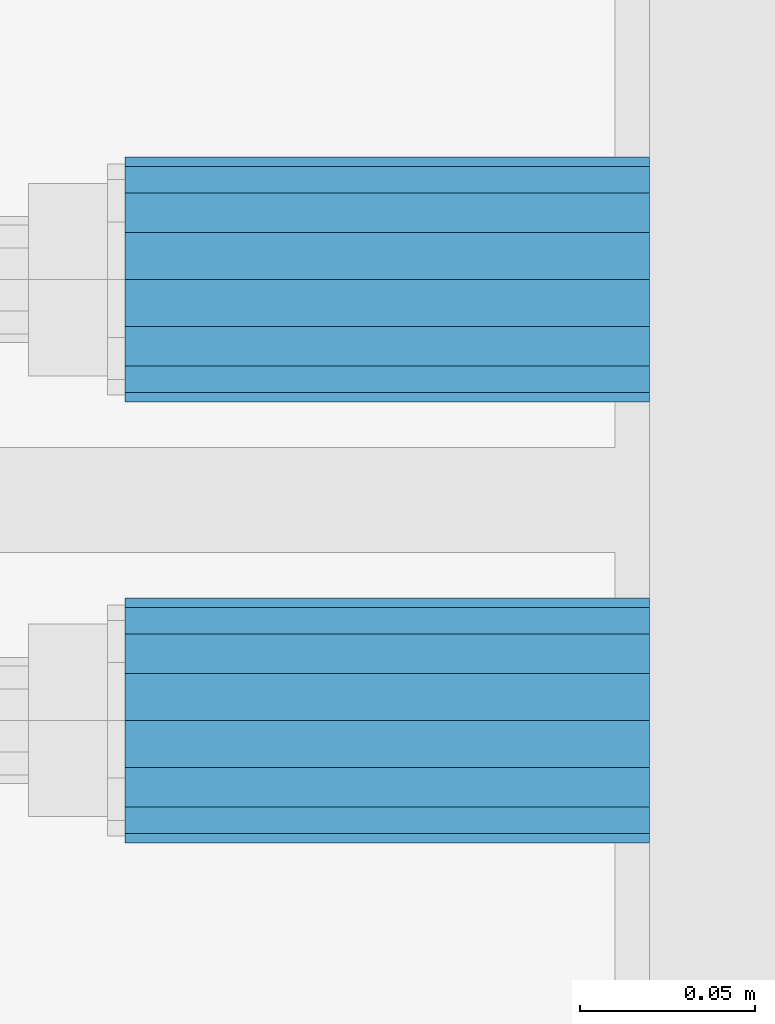
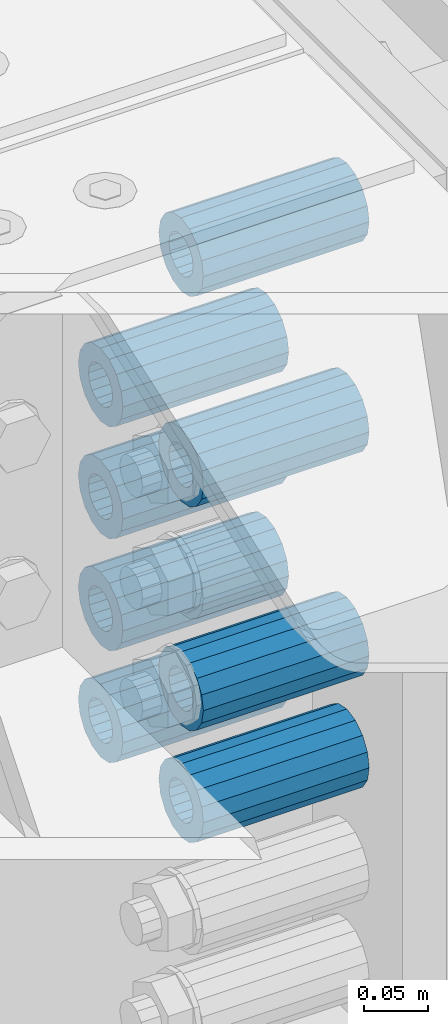
# One storey, part 159 of 242: 8 beams.
"""IFC2X3 building model written with IfcOpenShell, lengths in millimetres."""

from ifc_helpers import new_model, si_unit, frame, origin_with_axes, place, context, subcontext, project, spatial, faceted_brep, material, type_object, element, save


model = new_model("IFC2X3")

# Units and contexts
model_context = context("Model", 3, precision=1e-05, world=origin_with_axes())
body_context = subcontext(model_context, "Body", "Model", "MODEL_VIEW")
ifc_project = project(units=[si_unit("LENGTHUNIT", "METRE", prefix="MILLI"), si_unit("AREAUNIT", "SQUARE_METRE"), si_unit("VOLUMEUNIT", "CUBIC_METRE"), si_unit("MASSUNIT", "GRAM", prefix="KILO"), si_unit("TIMEUNIT", "SECOND"), si_unit("PLANEANGLEUNIT", "RADIAN"), si_unit("SOLIDANGLEUNIT", "STERADIAN"), si_unit("THERMODYNAMICTEMPERATUREUNIT", "DEGREE_CELSIUS"), si_unit("LUMINOUSINTENSITYUNIT", "LUMEN")], contexts=[model_context])

# Site, building, storey
site_placement = place(None, origin_with_axes())
site = spatial("IfcSite", under=ifc_project, at=site_placement, CompositionType="ELEMENT")
building_placement = place(site_placement, origin_with_axes())
building = spatial("IfcBuilding", under=site, at=building_placement, Name="Standard", CompositionType="ELEMENT")
storey_placement = place(building_placement, origin_with_axes())
storey = spatial("IfcBuildingStorey", under=building, at=storey_placement, Name="Undefined", CompositionType="ELEMENT", Elevation=0.0)

# Beams
ifc_material = material()
beam_type = type_object("IfcBeamType", PredefinedType="NOTDEFINED")
beam_1_placement = place(storey_placement, frame((-22210.0, -20937.0, -290.0), z_axis=(0.0, 0.0, 1.0), x_axis=(1.0, 0.0, 0.0)))
element("IfcBeam", 1, at=beam_1_placement, inside=storey, type_object=beam_type, material=ifc_material, context=body_context, shape_type="Brep", body=[
    faceted_brep([(1.33248249767348e-07, -19.0000000004493, -6.26823748461902e-09), (0.0, -17.5537111177146, 7.27098521493673), (150.0, -17.5537111177146, 7.27098521493673), (150.0, -19.0, 0.0), (0.0, -13.4350288425449, 13.4350288425444), (150.0, -13.4350288425449, 13.4350288425444), (0.0, -7.27098521493826, 17.5537111177144), (150.0, -7.27098521493826, 17.5537111177144), (-6.29370333626866e-09, -4.49290382675827e-10, 18.9999999937318), (150.0, 0.0, 19.0), (0.0, 7.27098521493826, 17.5537111177144), (150.0, 7.27098521493826, 17.5537111177144), (0.0, 13.4350288425449, 13.4350288425444), (150.0, 13.4350288425449, 13.4350288425444), (0.0, 17.5537111177146, 7.2709852149367), (150.0, 17.5537111177146, 7.2709852149367), (-1.31243723444641e-07, 18.9999999995507, -6.26823748461902e-09), (150.0, 19.0, 0.0), (0.0, 17.5537111177146, -7.2709852149367), (150.0, 17.5537111177146, -7.2709852149367), (0.0, 13.4350288425449, -13.4350288425444), (150.0, 13.4350288425449, -13.4350288425444), (0.0, 7.27098521493826, -17.5537111177144), (150.0, 7.27098521493826, -17.5537111177144), (8.2982296589762e-09, -4.49290382675827e-10, -19.0000000062719), (150.0, 0.0, -19.0), (0.0, -7.27098521493826, -17.5537111177144), (150.0, -7.27098521493826, -17.5537111177144), (0.0, -13.4350288425449, -13.4350288425444), (150.0, -13.4350288425449, -13.4350288425444), (0.0, -17.5537111177146, -7.2709852149367), (150.0, -17.5537111177146, -7.2709852149367), (-3.63797880709171e-12, -35.0, 0.0), (-3.63797880709171e-12, -32.335783637895, -13.3939201327812), (150.0, -32.3357836378964, -13.3939201327782), (150.0, -35.0, 0.0), (0.0, -24.7487373415292, -24.7487373415315), (150.0, -24.7487373415279, -24.7487373415292), (0.0, -13.3939201327782, -32.3357836378964), (150.0, -13.3939201327776, -32.335783637895), (0.0, 0.0, -35.0000000000036), (150.0, 0.0, -35.0), (0.0, 13.3939201327782, -32.3357836378964), (150.0, 13.3939201327776, -32.335783637895), (0.0, 24.7487373415292, -24.7487373415315), (150.0, 24.7487373415279, -24.7487373415292), (-3.63797880709171e-12, 32.335783637895, -13.3939201327812), (150.0, 32.3357836378964, -13.3939201327781), (-3.63797880709171e-12, 35.0, 0.0), (150.0, 35.0, 0.0), (-7.27595761418343e-12, 32.335783637895, 13.3939201327739), (150.0, 32.3357836378964, 13.3939201327781), (-7.27595761418343e-12, 24.7487373415292, 24.7487373415242), (150.0, 24.7487373415279, 24.7487373415292), (-7.27595761418343e-12, 13.3939201327781, 32.3357836378891), (150.0, 13.3939201327776, 32.335783637895), (-1.09139364212751e-11, 0.0, 34.9999999999964), (150.0, 0.0, 35.0), (-7.27595761418343e-12, -13.3939201327781, 32.3357836378891), (150.0, -13.3939201327776, 32.335783637895), (-7.27595761418343e-12, -24.7487373415292, 24.7487373415242), (150.0, -24.7487373415279, 24.7487373415292), (-7.27595761418343e-12, -32.335783637895, 13.3939201327739), (150.0, -32.3357836378964, 13.3939201327781)], [[[0, 1, 2, 3]], [[1, 4, 5, 2]], [[4, 6, 7, 5]], [[6, 8, 9, 7]], [[8, 10, 11, 9]], [[10, 12, 13, 11]], [[12, 14, 15, 13]], [[14, 16, 17, 15]], [[16, 18, 19, 17]], [[18, 20, 21, 19]], [[20, 22, 23, 21]], [[22, 24, 25, 23]], [[24, 26, 27, 25]], [[26, 28, 29, 27]], [[28, 30, 31, 29]], [[30, 0, 3, 31]], [[32, 33, 34, 35]], [[33, 36, 37, 34]], [[36, 38, 39, 37]], [[38, 40, 41, 39]], [[40, 42, 43, 41]], [[42, 44, 45, 43]], [[44, 46, 47, 45]], [[46, 48, 49, 47]], [[48, 50, 51, 49]], [[50, 52, 53, 51]], [[52, 54, 55, 53]], [[54, 56, 57, 55]], [[56, 58, 59, 57]], [[58, 60, 61, 59]], [[60, 62, 63, 61]], [[62, 32, 35, 63]], [[37, 39, 41, 43, 45, 47, 49, 51, 53, 55, 57, 59, 61, 63, 35, 34], [5, 7, 9, 11, 13, 15, 17, 19, 21, 23, 25, 27, 29, 31, 3, 2]], [[62, 60, 58, 56, 54, 52, 50, 48, 46, 44, 42, 40, 38, 36, 33, 32], [30, 28, 26, 24, 22, 20, 18, 16, 14, 12, 10, 8, 6, 4, 1, 0]]]),
])
beam_2_placement = place(storey_placement, frame((-22210.0, -20937.0, -504.0), z_axis=(0.0, 0.0, 1.0), x_axis=(1.0, 0.0, 0.0)))
element("IfcBeam", 2, at=beam_2_placement, inside=storey, type_object=beam_type, material=ifc_material, context=body_context, shape_type="Brep", body=[
    faceted_brep([(1.33248249767348e-07, -19.0000000004493, -6.26823748461902e-09), (0.0, -17.5537111177146, 7.27098521493673), (150.0, -17.5537111177146, 7.27098521493673), (150.0, -19.0, 0.0), (0.0, -13.4350288425449, 13.4350288425444), (150.0, -13.4350288425449, 13.4350288425444), (0.0, -7.27098521493826, 17.5537111177144), (150.0, -7.27098521493826, 17.5537111177144), (-6.29370333626866e-09, -4.49290382675827e-10, 18.9999999937318), (150.0, 0.0, 19.0), (0.0, 7.27098521493826, 17.5537111177144), (150.0, 7.27098521493826, 17.5537111177144), (0.0, 13.4350288425449, 13.4350288425444), (150.0, 13.4350288425449, 13.4350288425444), (0.0, 17.5537111177146, 7.2709852149367), (150.0, 17.5537111177146, 7.2709852149367), (-1.31243723444641e-07, 18.9999999995507, -6.26823748461902e-09), (150.0, 19.0, 0.0), (0.0, 17.5537111177146, -7.2709852149367), (150.0, 17.5537111177146, -7.2709852149367), (0.0, 13.4350288425449, -13.4350288425444), (150.0, 13.4350288425449, -13.4350288425444), (0.0, 7.27098521493826, -17.5537111177144), (150.0, 7.27098521493826, -17.5537111177144), (8.2982296589762e-09, -4.49290382675827e-10, -19.0000000062719), (150.0, 0.0, -19.0), (0.0, -7.27098521493826, -17.5537111177144), (150.0, -7.27098521493826, -17.5537111177144), (0.0, -13.4350288425449, -13.4350288425444), (150.0, -13.4350288425449, -13.4350288425444), (0.0, -17.5537111177146, -7.2709852149367), (150.0, -17.5537111177146, -7.2709852149367), (-3.63797880709171e-12, -35.0, 0.0), (-3.63797880709171e-12, -32.335783637895, -13.3939201327812), (150.0, -32.3357836378964, -13.3939201327782), (150.0, -35.0, 0.0), (0.0, -24.7487373415292, -24.7487373415315), (150.0, -24.7487373415279, -24.7487373415292), (0.0, -13.3939201327782, -32.3357836378964), (150.0, -13.3939201327776, -32.335783637895), (0.0, 0.0, -35.0000000000036), (150.0, 0.0, -35.0), (0.0, 13.3939201327782, -32.3357836378964), (150.0, 13.3939201327776, -32.335783637895), (0.0, 24.7487373415292, -24.7487373415315), (150.0, 24.7487373415279, -24.7487373415292), (-3.63797880709171e-12, 32.335783637895, -13.3939201327812), (150.0, 32.3357836378964, -13.3939201327781), (-3.63797880709171e-12, 35.0, 0.0), (150.0, 35.0, 0.0), (-7.27595761418343e-12, 32.335783637895, 13.3939201327739), (150.0, 32.3357836378964, 13.3939201327781), (-7.27595761418343e-12, 24.7487373415292, 24.7487373415242), (150.0, 24.7487373415279, 24.7487373415292), (-7.27595761418343e-12, 13.3939201327781, 32.3357836378891), (150.0, 13.3939201327776, 32.335783637895), (-1.09139364212751e-11, 0.0, 34.9999999999964), (150.0, 0.0, 35.0), (-7.27595761418343e-12, -13.3939201327781, 32.3357836378891), (150.0, -13.3939201327776, 32.335783637895), (-7.27595761418343e-12, -24.7487373415292, 24.7487373415242), (150.0, -24.7487373415279, 24.7487373415292), (-7.27595761418343e-12, -32.335783637895, 13.3939201327739), (150.0, -32.3357836378964, 13.3939201327781)], [[[0, 1, 2, 3]], [[1, 4, 5, 2]], [[4, 6, 7, 5]], [[6, 8, 9, 7]], [[8, 10, 11, 9]], [[10, 12, 13, 11]], [[12, 14, 15, 13]], [[14, 16, 17, 15]], [[16, 18, 19, 17]], [[18, 20, 21, 19]], [[20, 22, 23, 21]], [[22, 24, 25, 23]], [[24, 26, 27, 25]], [[26, 28, 29, 27]], [[28, 30, 31, 29]], [[30, 0, 3, 31]], [[32, 33, 34, 35]], [[33, 36, 37, 34]], [[36, 38, 39, 37]], [[38, 40, 41, 39]], [[40, 42, 43, 41]], [[42, 44, 45, 43]], [[44, 46, 47, 45]], [[46, 48, 49, 47]], [[48, 50, 51, 49]], [[50, 52, 53, 51]], [[52, 54, 55, 53]], [[54, 56, 57, 55]], [[56, 58, 59, 57]], [[58, 60, 61, 59]], [[60, 62, 63, 61]], [[62, 32, 35, 63]], [[37, 39, 41, 43, 45, 47, 49, 51, 53, 55, 57, 59, 61, 63, 35, 34], [5, 7, 9, 11, 13, 15, 17, 19, 21, 23, 25, 27, 29, 31, 3, 2]], [[62, 60, 58, 56, 54, 52, 50, 48, 46, 44, 42, 40, 38, 36, 33, 32], [30, 28, 26, 24, 22, 20, 18, 16, 14, 12, 10, 8, 6, 4, 1, 0]]]),
])
beam_3_placement = place(storey_placement, frame((-22210.0, -20937.0, -611.0), z_axis=(0.0, 0.0, 1.0), x_axis=(1.0, 0.0, 0.0)))
element("IfcBeam", 3, at=beam_3_placement, inside=storey, type_object=beam_type, material=ifc_material, context=body_context, shape_type="Brep", body=[
    faceted_brep([(1.33248249767348e-07, -19.0000000004493, -6.26823748461902e-09), (0.0, -17.5537111177146, 7.27098521493673), (150.0, -17.5537111177146, 7.27098521493673), (150.0, -19.0, 0.0), (0.0, -13.4350288425449, 13.4350288425444), (150.0, -13.4350288425449, 13.4350288425444), (0.0, -7.27098521493826, 17.5537111177144), (150.0, -7.27098521493826, 17.5537111177144), (-6.29370333626866e-09, -4.49290382675827e-10, 18.9999999937318), (150.0, 0.0, 19.0), (0.0, 7.27098521493826, 17.5537111177144), (150.0, 7.27098521493826, 17.5537111177144), (0.0, 13.4350288425449, 13.4350288425444), (150.0, 13.4350288425449, 13.4350288425444), (0.0, 17.5537111177146, 7.2709852149367), (150.0, 17.5537111177146, 7.2709852149367), (-1.31243723444641e-07, 18.9999999995507, -6.26823748461902e-09), (150.0, 19.0, 0.0), (0.0, 17.5537111177146, -7.2709852149367), (150.0, 17.5537111177146, -7.2709852149367), (0.0, 13.4350288425449, -13.4350288425444), (150.0, 13.4350288425449, -13.4350288425444), (0.0, 7.27098521493826, -17.5537111177144), (150.0, 7.27098521493826, -17.5537111177144), (8.2982296589762e-09, -4.49290382675827e-10, -19.0000000062719), (150.0, 0.0, -19.0), (0.0, -7.27098521493826, -17.5537111177144), (150.0, -7.27098521493826, -17.5537111177144), (0.0, -13.4350288425449, -13.4350288425444), (150.0, -13.4350288425449, -13.4350288425444), (0.0, -17.5537111177146, -7.2709852149367), (150.0, -17.5537111177146, -7.2709852149367), (-3.63797880709171e-12, -35.0, 0.0), (-3.63797880709171e-12, -32.335783637895, -13.3939201327812), (150.0, -32.3357836378964, -13.3939201327782), (150.0, -35.0, 0.0), (0.0, -24.7487373415292, -24.7487373415315), (150.0, -24.7487373415279, -24.7487373415292), (0.0, -13.3939201327782, -32.3357836378964), (150.0, -13.3939201327776, -32.335783637895), (0.0, 0.0, -35.0000000000036), (150.0, 0.0, -35.0), (0.0, 13.3939201327782, -32.3357836378964), (150.0, 13.3939201327776, -32.335783637895), (0.0, 24.7487373415292, -24.7487373415315), (150.0, 24.7487373415279, -24.7487373415292), (-3.63797880709171e-12, 32.335783637895, -13.3939201327812), (150.0, 32.3357836378964, -13.3939201327781), (-3.63797880709171e-12, 35.0, 0.0), (150.0, 35.0, 0.0), (-7.27595761418343e-12, 32.335783637895, 13.3939201327739), (150.0, 32.3357836378964, 13.3939201327781), (-7.27595761418343e-12, 24.7487373415292, 24.7487373415242), (150.0, 24.7487373415279, 24.7487373415292), (-7.27595761418343e-12, 13.3939201327781, 32.3357836378891), (150.0, 13.3939201327776, 32.335783637895), (-1.09139364212751e-11, 0.0, 34.9999999999964), (150.0, 0.0, 35.0), (-7.27595761418343e-12, -13.3939201327781, 32.3357836378891), (150.0, -13.3939201327776, 32.335783637895), (-7.27595761418343e-12, -24.7487373415292, 24.7487373415242), (150.0, -24.7487373415279, 24.7487373415292), (-7.27595761418343e-12, -32.335783637895, 13.3939201327739), (150.0, -32.3357836378964, 13.3939201327781)], [[[0, 1, 2, 3]], [[1, 4, 5, 2]], [[4, 6, 7, 5]], [[6, 8, 9, 7]], [[8, 10, 11, 9]], [[10, 12, 13, 11]], [[12, 14, 15, 13]], [[14, 16, 17, 15]], [[16, 18, 19, 17]], [[18, 20, 21, 19]], [[20, 22, 23, 21]], [[22, 24, 25, 23]], [[24, 26, 27, 25]], [[26, 28, 29, 27]], [[28, 30, 31, 29]], [[30, 0, 3, 31]], [[32, 33, 34, 35]], [[33, 36, 37, 34]], [[36, 38, 39, 37]], [[38, 40, 41, 39]], [[40, 42, 43, 41]], [[42, 44, 45, 43]], [[44, 46, 47, 45]], [[46, 48, 49, 47]], [[48, 50, 51, 49]], [[50, 52, 53, 51]], [[52, 54, 55, 53]], [[54, 56, 57, 55]], [[56, 58, 59, 57]], [[58, 60, 61, 59]], [[60, 62, 63, 61]], [[62, 32, 35, 63]], [[37, 39, 41, 43, 45, 47, 49, 51, 53, 55, 57, 59, 61, 63, 35, 34], [5, 7, 9, 11, 13, 15, 17, 19, 21, 23, 25, 27, 29, 31, 3, 2]], [[62, 60, 58, 56, 54, 52, 50, 48, 46, 44, 42, 40, 38, 36, 33, 32], [30, 28, 26, 24, 22, 20, 18, 16, 14, 12, 10, 8, 6, 4, 1, 0]]]),
])
beam_4_placement = place(storey_placement, frame((-22210.0, -21063.0, -89.0000000000001), z_axis=(0.0, 0.0, 1.0), x_axis=(1.0, 0.0, 0.0)))
element("IfcBeam", 4, at=beam_4_placement, inside=storey, type_object=beam_type, material=ifc_material, context=body_context, shape_type="Brep", body=[
    faceted_brep([(1.33248249767348e-07, -19.0000000004493, -6.26823748461902e-09), (0.0, -17.5537111177146, 7.27098521493673), (150.0, -17.5537111177146, 7.27098521493673), (150.0, -19.0, 0.0), (0.0, -13.4350288425449, 13.4350288425444), (150.0, -13.4350288425449, 13.4350288425444), (0.0, -7.27098521493826, 17.5537111177144), (150.0, -7.27098521493826, 17.5537111177144), (-6.29370333626866e-09, -4.49290382675827e-10, 18.9999999937318), (150.0, 0.0, 19.0), (0.0, 7.27098521493826, 17.5537111177144), (150.0, 7.27098521493826, 17.5537111177144), (0.0, 13.4350288425449, 13.4350288425444), (150.0, 13.4350288425449, 13.4350288425444), (0.0, 17.5537111177146, 7.2709852149367), (150.0, 17.5537111177146, 7.2709852149367), (-1.31243723444641e-07, 18.9999999995507, -6.26823748461902e-09), (150.0, 19.0, 0.0), (0.0, 17.5537111177146, -7.2709852149367), (150.0, 17.5537111177146, -7.2709852149367), (0.0, 13.4350288425449, -13.4350288425444), (150.0, 13.4350288425449, -13.4350288425444), (0.0, 7.27098521493826, -17.5537111177144), (150.0, 7.27098521493826, -17.5537111177144), (8.2982296589762e-09, -4.49290382675827e-10, -19.0000000062719), (150.0, 0.0, -19.0), (0.0, -7.27098521493826, -17.5537111177144), (150.0, -7.27098521493826, -17.5537111177144), (0.0, -13.4350288425449, -13.4350288425444), (150.0, -13.4350288425449, -13.4350288425444), (0.0, -17.5537111177146, -7.2709852149367), (150.0, -17.5537111177146, -7.2709852149367), (-3.63797880709171e-12, -35.0, 0.0), (-3.63797880709171e-12, -32.335783637895, -13.3939201327812), (150.0, -32.3357836378964, -13.3939201327782), (150.0, -35.0, 0.0), (0.0, -24.7487373415292, -24.7487373415315), (150.0, -24.7487373415279, -24.7487373415292), (0.0, -13.3939201327782, -32.3357836378964), (150.0, -13.3939201327776, -32.335783637895), (0.0, 0.0, -35.0000000000036), (150.0, 0.0, -35.0), (0.0, 13.3939201327782, -32.3357836378964), (150.0, 13.3939201327776, -32.335783637895), (0.0, 24.7487373415292, -24.7487373415315), (150.0, 24.7487373415279, -24.7487373415292), (-3.63797880709171e-12, 32.335783637895, -13.3939201327812), (150.0, 32.3357836378964, -13.3939201327781), (-3.63797880709171e-12, 35.0, 0.0), (150.0, 35.0, 0.0), (-7.27595761418343e-12, 32.335783637895, 13.3939201327739), (150.0, 32.3357836378964, 13.3939201327781), (-7.27595761418343e-12, 24.7487373415292, 24.7487373415242), (150.0, 24.7487373415279, 24.7487373415292), (-7.27595761418343e-12, 13.3939201327781, 32.3357836378891), (150.0, 13.3939201327776, 32.335783637895), (-1.09139364212751e-11, 0.0, 34.9999999999964), (150.0, 0.0, 35.0), (-7.27595761418343e-12, -13.3939201327781, 32.3357836378891), (150.0, -13.3939201327776, 32.335783637895), (-7.27595761418343e-12, -24.7487373415292, 24.7487373415242), (150.0, -24.7487373415279, 24.7487373415292), (-7.27595761418343e-12, -32.335783637895, 13.3939201327739), (150.0, -32.3357836378964, 13.3939201327781)], [[[0, 1, 2, 3]], [[1, 4, 5, 2]], [[4, 6, 7, 5]], [[6, 8, 9, 7]], [[8, 10, 11, 9]], [[10, 12, 13, 11]], [[12, 14, 15, 13]], [[14, 16, 17, 15]], [[16, 18, 19, 17]], [[18, 20, 21, 19]], [[20, 22, 23, 21]], [[22, 24, 25, 23]], [[24, 26, 27, 25]], [[26, 28, 29, 27]], [[28, 30, 31, 29]], [[30, 0, 3, 31]], [[32, 33, 34, 35]], [[33, 36, 37, 34]], [[36, 38, 39, 37]], [[38, 40, 41, 39]], [[40, 42, 43, 41]], [[42, 44, 45, 43]], [[44, 46, 47, 45]], [[46, 48, 49, 47]], [[48, 50, 51, 49]], [[50, 52, 53, 51]], [[52, 54, 55, 53]], [[54, 56, 57, 55]], [[56, 58, 59, 57]], [[58, 60, 61, 59]], [[60, 62, 63, 61]], [[62, 32, 35, 63]], [[37, 39, 41, 43, 45, 47, 49, 51, 53, 55, 57, 59, 61, 63, 35, 34], [5, 7, 9, 11, 13, 15, 17, 19, 21, 23, 25, 27, 29, 31, 3, 2]], [[62, 60, 58, 56, 54, 52, 50, 48, 46, 44, 42, 40, 38, 36, 33, 32], [30, 28, 26, 24, 22, 20, 18, 16, 14, 12, 10, 8, 6, 4, 1, 0]]]),
])
beam_5_placement = place(storey_placement, frame((-22210.0, -20937.0, -397.0), z_axis=(0.0, 0.0, 1.0), x_axis=(1.0, 0.0, 0.0)))
element("IfcBeam", 5, at=beam_5_placement, inside=storey, type_object=beam_type, material=ifc_material, context=body_context, shape_type="Brep", body=[
    faceted_brep([(1.33248249767348e-07, -19.0000000004493, -6.26823748461902e-09), (0.0, -17.5537111177146, 7.27098521493673), (150.0, -17.5537111177146, 7.27098521493673), (150.0, -19.0, 0.0), (0.0, -13.4350288425449, 13.4350288425444), (150.0, -13.4350288425449, 13.4350288425444), (0.0, -7.27098521493826, 17.5537111177144), (150.0, -7.27098521493826, 17.5537111177144), (-6.29370333626866e-09, -4.49290382675827e-10, 18.9999999937318), (150.0, 0.0, 19.0), (0.0, 7.27098521493826, 17.5537111177144), (150.0, 7.27098521493826, 17.5537111177144), (0.0, 13.4350288425449, 13.4350288425444), (150.0, 13.4350288425449, 13.4350288425444), (0.0, 17.5537111177146, 7.2709852149367), (150.0, 17.5537111177146, 7.2709852149367), (-1.31243723444641e-07, 18.9999999995507, -6.26823748461902e-09), (150.0, 19.0, 0.0), (0.0, 17.5537111177146, -7.2709852149367), (150.0, 17.5537111177146, -7.2709852149367), (0.0, 13.4350288425449, -13.4350288425444), (150.0, 13.4350288425449, -13.4350288425444), (0.0, 7.27098521493826, -17.5537111177144), (150.0, 7.27098521493826, -17.5537111177144), (8.2982296589762e-09, -4.49290382675827e-10, -19.0000000062719), (150.0, 0.0, -19.0), (0.0, -7.27098521493826, -17.5537111177144), (150.0, -7.27098521493826, -17.5537111177144), (0.0, -13.4350288425449, -13.4350288425444), (150.0, -13.4350288425449, -13.4350288425444), (0.0, -17.5537111177146, -7.2709852149367), (150.0, -17.5537111177146, -7.2709852149367), (-3.63797880709171e-12, -35.0, 0.0), (-3.63797880709171e-12, -32.335783637895, -13.3939201327812), (150.0, -32.3357836378964, -13.3939201327782), (150.0, -35.0, 0.0), (0.0, -24.7487373415292, -24.7487373415315), (150.0, -24.7487373415279, -24.7487373415292), (0.0, -13.3939201327782, -32.3357836378964), (150.0, -13.3939201327776, -32.335783637895), (0.0, 0.0, -35.0000000000036), (150.0, 0.0, -35.0), (0.0, 13.3939201327782, -32.3357836378964), (150.0, 13.3939201327776, -32.335783637895), (0.0, 24.7487373415292, -24.7487373415315), (150.0, 24.7487373415279, -24.7487373415292), (-3.63797880709171e-12, 32.335783637895, -13.3939201327812), (150.0, 32.3357836378964, -13.3939201327781), (-3.63797880709171e-12, 35.0, 0.0), (150.0, 35.0, 0.0), (-7.27595761418343e-12, 32.335783637895, 13.3939201327739), (150.0, 32.3357836378964, 13.3939201327781), (-7.27595761418343e-12, 24.7487373415292, 24.7487373415242), (150.0, 24.7487373415279, 24.7487373415292), (-7.27595761418343e-12, 13.3939201327781, 32.3357836378891), (150.0, 13.3939201327776, 32.335783637895), (-1.09139364212751e-11, 0.0, 34.9999999999964), (150.0, 0.0, 35.0), (-7.27595761418343e-12, -13.3939201327781, 32.3357836378891), (150.0, -13.3939201327776, 32.335783637895), (-7.27595761418343e-12, -24.7487373415292, 24.7487373415242), (150.0, -24.7487373415279, 24.7487373415292), (-7.27595761418343e-12, -32.335783637895, 13.3939201327739), (150.0, -32.3357836378964, 13.3939201327781)], [[[0, 1, 2, 3]], [[1, 4, 5, 2]], [[4, 6, 7, 5]], [[6, 8, 9, 7]], [[8, 10, 11, 9]], [[10, 12, 13, 11]], [[12, 14, 15, 13]], [[14, 16, 17, 15]], [[16, 18, 19, 17]], [[18, 20, 21, 19]], [[20, 22, 23, 21]], [[22, 24, 25, 23]], [[24, 26, 27, 25]], [[26, 28, 29, 27]], [[28, 30, 31, 29]], [[30, 0, 3, 31]], [[32, 33, 34, 35]], [[33, 36, 37, 34]], [[36, 38, 39, 37]], [[38, 40, 41, 39]], [[40, 42, 43, 41]], [[42, 44, 45, 43]], [[44, 46, 47, 45]], [[46, 48, 49, 47]], [[48, 50, 51, 49]], [[50, 52, 53, 51]], [[52, 54, 55, 53]], [[54, 56, 57, 55]], [[56, 58, 59, 57]], [[58, 60, 61, 59]], [[60, 62, 63, 61]], [[62, 32, 35, 63]], [[37, 39, 41, 43, 45, 47, 49, 51, 53, 55, 57, 59, 61, 63, 35, 34], [5, 7, 9, 11, 13, 15, 17, 19, 21, 23, 25, 27, 29, 31, 3, 2]], [[62, 60, 58, 56, 54, 52, 50, 48, 46, 44, 42, 40, 38, 36, 33, 32], [30, 28, 26, 24, 22, 20, 18, 16, 14, 12, 10, 8, 6, 4, 1, 0]]]),
])
beam_6_placement = place(storey_placement, frame((-22210.0, -21063.0, -290.0), z_axis=(0.0, 0.0, 1.0), x_axis=(1.0, 0.0, 0.0)))
element("IfcBeam", 6, at=beam_6_placement, inside=storey, type_object=beam_type, material=ifc_material, context=body_context, shape_type="Brep", body=[
    faceted_brep([(1.33248249767348e-07, -19.0000000004493, -6.26823748461902e-09), (0.0, -17.5537111177146, 7.27098521493673), (150.0, -17.5537111177146, 7.27098521493673), (150.0, -19.0, 0.0), (0.0, -13.4350288425449, 13.4350288425444), (150.0, -13.4350288425449, 13.4350288425444), (0.0, -7.27098521493826, 17.5537111177144), (150.0, -7.27098521493826, 17.5537111177144), (-6.29370333626866e-09, -4.49290382675827e-10, 18.9999999937318), (150.0, 0.0, 19.0), (0.0, 7.27098521493826, 17.5537111177144), (150.0, 7.27098521493826, 17.5537111177144), (0.0, 13.4350288425449, 13.4350288425444), (150.0, 13.4350288425449, 13.4350288425444), (0.0, 17.5537111177146, 7.2709852149367), (150.0, 17.5537111177146, 7.2709852149367), (-1.31243723444641e-07, 18.9999999995507, -6.26823748461902e-09), (150.0, 19.0, 0.0), (0.0, 17.5537111177146, -7.2709852149367), (150.0, 17.5537111177146, -7.2709852149367), (0.0, 13.4350288425449, -13.4350288425444), (150.0, 13.4350288425449, -13.4350288425444), (0.0, 7.27098521493826, -17.5537111177144), (150.0, 7.27098521493826, -17.5537111177144), (8.2982296589762e-09, -4.49290382675827e-10, -19.0000000062719), (150.0, 0.0, -19.0), (0.0, -7.27098521493826, -17.5537111177144), (150.0, -7.27098521493826, -17.5537111177144), (0.0, -13.4350288425449, -13.4350288425444), (150.0, -13.4350288425449, -13.4350288425444), (0.0, -17.5537111177146, -7.2709852149367), (150.0, -17.5537111177146, -7.2709852149367), (-3.63797880709171e-12, -35.0, 0.0), (-3.63797880709171e-12, -32.335783637895, -13.3939201327812), (150.0, -32.3357836378964, -13.3939201327782), (150.0, -35.0, 0.0), (0.0, -24.7487373415292, -24.7487373415315), (150.0, -24.7487373415279, -24.7487373415292), (0.0, -13.3939201327782, -32.3357836378964), (150.0, -13.3939201327776, -32.335783637895), (0.0, 0.0, -35.0000000000036), (150.0, 0.0, -35.0), (0.0, 13.3939201327782, -32.3357836378964), (150.0, 13.3939201327776, -32.335783637895), (0.0, 24.7487373415292, -24.7487373415315), (150.0, 24.7487373415279, -24.7487373415292), (-3.63797880709171e-12, 32.335783637895, -13.3939201327812), (150.0, 32.3357836378964, -13.3939201327781), (-3.63797880709171e-12, 35.0, 0.0), (150.0, 35.0, 0.0), (-7.27595761418343e-12, 32.335783637895, 13.3939201327739), (150.0, 32.3357836378964, 13.3939201327781), (-7.27595761418343e-12, 24.7487373415292, 24.7487373415242), (150.0, 24.7487373415279, 24.7487373415292), (-7.27595761418343e-12, 13.3939201327781, 32.3357836378891), (150.0, 13.3939201327776, 32.335783637895), (-1.09139364212751e-11, 0.0, 34.9999999999964), (150.0, 0.0, 35.0), (-7.27595761418343e-12, -13.3939201327781, 32.3357836378891), (150.0, -13.3939201327776, 32.335783637895), (-7.27595761418343e-12, -24.7487373415292, 24.7487373415242), (150.0, -24.7487373415279, 24.7487373415292), (-7.27595761418343e-12, -32.335783637895, 13.3939201327739), (150.0, -32.3357836378964, 13.3939201327781)], [[[0, 1, 2, 3]], [[1, 4, 5, 2]], [[4, 6, 7, 5]], [[6, 8, 9, 7]], [[8, 10, 11, 9]], [[10, 12, 13, 11]], [[12, 14, 15, 13]], [[14, 16, 17, 15]], [[16, 18, 19, 17]], [[18, 20, 21, 19]], [[20, 22, 23, 21]], [[22, 24, 25, 23]], [[24, 26, 27, 25]], [[26, 28, 29, 27]], [[28, 30, 31, 29]], [[30, 0, 3, 31]], [[32, 33, 34, 35]], [[33, 36, 37, 34]], [[36, 38, 39, 37]], [[38, 40, 41, 39]], [[40, 42, 43, 41]], [[42, 44, 45, 43]], [[44, 46, 47, 45]], [[46, 48, 49, 47]], [[48, 50, 51, 49]], [[50, 52, 53, 51]], [[52, 54, 55, 53]], [[54, 56, 57, 55]], [[56, 58, 59, 57]], [[58, 60, 61, 59]], [[60, 62, 63, 61]], [[62, 32, 35, 63]], [[37, 39, 41, 43, 45, 47, 49, 51, 53, 55, 57, 59, 61, 63, 35, 34], [5, 7, 9, 11, 13, 15, 17, 19, 21, 23, 25, 27, 29, 31, 3, 2]], [[62, 60, 58, 56, 54, 52, 50, 48, 46, 44, 42, 40, 38, 36, 33, 32], [30, 28, 26, 24, 22, 20, 18, 16, 14, 12, 10, 8, 6, 4, 1, 0]]]),
])
beam_7_placement = place(storey_placement, frame((-22210.0, -21063.0, -504.0), z_axis=(0.0, 0.0, 1.0), x_axis=(1.0, 0.0, 0.0)))
element("IfcBeam", 7, at=beam_7_placement, inside=storey, type_object=beam_type, material=ifc_material, context=body_context, shape_type="Brep", body=[
    faceted_brep([(1.33248249767348e-07, -19.0000000004493, -6.26823748461902e-09), (0.0, -17.5537111177146, 7.27098521493673), (150.0, -17.5537111177146, 7.27098521493673), (150.0, -19.0, 0.0), (0.0, -13.4350288425449, 13.4350288425444), (150.0, -13.4350288425449, 13.4350288425444), (0.0, -7.27098521493826, 17.5537111177144), (150.0, -7.27098521493826, 17.5537111177144), (-6.29370333626866e-09, -4.49290382675827e-10, 18.9999999937318), (150.0, 0.0, 19.0), (0.0, 7.27098521493826, 17.5537111177144), (150.0, 7.27098521493826, 17.5537111177144), (0.0, 13.4350288425449, 13.4350288425444), (150.0, 13.4350288425449, 13.4350288425444), (0.0, 17.5537111177146, 7.2709852149367), (150.0, 17.5537111177146, 7.2709852149367), (-1.31243723444641e-07, 18.9999999995507, -6.26823748461902e-09), (150.0, 19.0, 0.0), (0.0, 17.5537111177146, -7.2709852149367), (150.0, 17.5537111177146, -7.2709852149367), (0.0, 13.4350288425449, -13.4350288425444), (150.0, 13.4350288425449, -13.4350288425444), (0.0, 7.27098521493826, -17.5537111177144), (150.0, 7.27098521493826, -17.5537111177144), (8.2982296589762e-09, -4.49290382675827e-10, -19.0000000062719), (150.0, 0.0, -19.0), (0.0, -7.27098521493826, -17.5537111177144), (150.0, -7.27098521493826, -17.5537111177144), (0.0, -13.4350288425449, -13.4350288425444), (150.0, -13.4350288425449, -13.4350288425444), (0.0, -17.5537111177146, -7.2709852149367), (150.0, -17.5537111177146, -7.2709852149367), (-3.63797880709171e-12, -35.0, 0.0), (-3.63797880709171e-12, -32.335783637895, -13.3939201327812), (150.0, -32.3357836378964, -13.3939201327782), (150.0, -35.0, 0.0), (0.0, -24.7487373415292, -24.7487373415315), (150.0, -24.7487373415279, -24.7487373415292), (0.0, -13.3939201327782, -32.3357836378964), (150.0, -13.3939201327776, -32.335783637895), (0.0, 0.0, -35.0000000000036), (150.0, 0.0, -35.0), (0.0, 13.3939201327782, -32.3357836378964), (150.0, 13.3939201327776, -32.335783637895), (0.0, 24.7487373415292, -24.7487373415315), (150.0, 24.7487373415279, -24.7487373415292), (-3.63797880709171e-12, 32.335783637895, -13.3939201327812), (150.0, 32.3357836378964, -13.3939201327781), (-3.63797880709171e-12, 35.0, 0.0), (150.0, 35.0, 0.0), (-7.27595761418343e-12, 32.335783637895, 13.3939201327739), (150.0, 32.3357836378964, 13.3939201327781), (-7.27595761418343e-12, 24.7487373415292, 24.7487373415242), (150.0, 24.7487373415279, 24.7487373415292), (-7.27595761418343e-12, 13.3939201327781, 32.3357836378891), (150.0, 13.3939201327776, 32.335783637895), (-1.09139364212751e-11, 0.0, 34.9999999999964), (150.0, 0.0, 35.0), (-7.27595761418343e-12, -13.3939201327781, 32.3357836378891), (150.0, -13.3939201327776, 32.335783637895), (-7.27595761418343e-12, -24.7487373415292, 24.7487373415242), (150.0, -24.7487373415279, 24.7487373415292), (-7.27595761418343e-12, -32.335783637895, 13.3939201327739), (150.0, -32.3357836378964, 13.3939201327781)], [[[0, 1, 2, 3]], [[1, 4, 5, 2]], [[4, 6, 7, 5]], [[6, 8, 9, 7]], [[8, 10, 11, 9]], [[10, 12, 13, 11]], [[12, 14, 15, 13]], [[14, 16, 17, 15]], [[16, 18, 19, 17]], [[18, 20, 21, 19]], [[20, 22, 23, 21]], [[22, 24, 25, 23]], [[24, 26, 27, 25]], [[26, 28, 29, 27]], [[28, 30, 31, 29]], [[30, 0, 3, 31]], [[32, 33, 34, 35]], [[33, 36, 37, 34]], [[36, 38, 39, 37]], [[38, 40, 41, 39]], [[40, 42, 43, 41]], [[42, 44, 45, 43]], [[44, 46, 47, 45]], [[46, 48, 49, 47]], [[48, 50, 51, 49]], [[50, 52, 53, 51]], [[52, 54, 55, 53]], [[54, 56, 57, 55]], [[56, 58, 59, 57]], [[58, 60, 61, 59]], [[60, 62, 63, 61]], [[62, 32, 35, 63]], [[37, 39, 41, 43, 45, 47, 49, 51, 53, 55, 57, 59, 61, 63, 35, 34], [5, 7, 9, 11, 13, 15, 17, 19, 21, 23, 25, 27, 29, 31, 3, 2]], [[62, 60, 58, 56, 54, 52, 50, 48, 46, 44, 42, 40, 38, 36, 33, 32], [30, 28, 26, 24, 22, 20, 18, 16, 14, 12, 10, 8, 6, 4, 1, 0]]]),
])
beam_8_placement = place(storey_placement, frame((-22210.0, -21063.0, -611.0), z_axis=(0.0, 0.0, 1.0), x_axis=(1.0, 0.0, 0.0)))
element("IfcBeam", 8, at=beam_8_placement, inside=storey, type_object=beam_type, material=ifc_material, context=body_context, shape_type="Brep", body=[
    faceted_brep([(1.33248249767348e-07, -19.0000000004493, -6.26823748461902e-09), (0.0, -17.5537111177146, 7.27098521493673), (150.0, -17.5537111177146, 7.27098521493673), (150.0, -19.0, 0.0), (0.0, -13.4350288425449, 13.4350288425444), (150.0, -13.4350288425449, 13.4350288425444), (0.0, -7.27098521493826, 17.5537111177144), (150.0, -7.27098521493826, 17.5537111177144), (-6.29370333626866e-09, -4.49290382675827e-10, 18.9999999937318), (150.0, 0.0, 19.0), (0.0, 7.27098521493826, 17.5537111177144), (150.0, 7.27098521493826, 17.5537111177144), (0.0, 13.4350288425449, 13.4350288425444), (150.0, 13.4350288425449, 13.4350288425444), (0.0, 17.5537111177146, 7.2709852149367), (150.0, 17.5537111177146, 7.2709852149367), (-1.31243723444641e-07, 18.9999999995507, -6.26823748461902e-09), (150.0, 19.0, 0.0), (0.0, 17.5537111177146, -7.2709852149367), (150.0, 17.5537111177146, -7.2709852149367), (0.0, 13.4350288425449, -13.4350288425444), (150.0, 13.4350288425449, -13.4350288425444), (0.0, 7.27098521493826, -17.5537111177144), (150.0, 7.27098521493826, -17.5537111177144), (8.2982296589762e-09, -4.49290382675827e-10, -19.0000000062719), (150.0, 0.0, -19.0), (0.0, -7.27098521493826, -17.5537111177144), (150.0, -7.27098521493826, -17.5537111177144), (0.0, -13.4350288425449, -13.4350288425444), (150.0, -13.4350288425449, -13.4350288425444), (0.0, -17.5537111177146, -7.2709852149367), (150.0, -17.5537111177146, -7.2709852149367), (-3.63797880709171e-12, -35.0, 0.0), (-3.63797880709171e-12, -32.335783637895, -13.3939201327812), (150.0, -32.3357836378964, -13.3939201327782), (150.0, -35.0, 0.0), (0.0, -24.7487373415292, -24.7487373415315), (150.0, -24.7487373415279, -24.7487373415292), (0.0, -13.3939201327782, -32.3357836378964), (150.0, -13.3939201327776, -32.335783637895), (0.0, 0.0, -35.0000000000036), (150.0, 0.0, -35.0), (0.0, 13.3939201327782, -32.3357836378964), (150.0, 13.3939201327776, -32.335783637895), (0.0, 24.7487373415292, -24.7487373415315), (150.0, 24.7487373415279, -24.7487373415292), (-3.63797880709171e-12, 32.335783637895, -13.3939201327812), (150.0, 32.3357836378964, -13.3939201327781), (-3.63797880709171e-12, 35.0, 0.0), (150.0, 35.0, 0.0), (-7.27595761418343e-12, 32.335783637895, 13.3939201327739), (150.0, 32.3357836378964, 13.3939201327781), (-7.27595761418343e-12, 24.7487373415292, 24.7487373415242), (150.0, 24.7487373415279, 24.7487373415292), (-7.27595761418343e-12, 13.3939201327781, 32.3357836378891), (150.0, 13.3939201327776, 32.335783637895), (-1.09139364212751e-11, 0.0, 34.9999999999964), (150.0, 0.0, 35.0), (-7.27595761418343e-12, -13.3939201327781, 32.3357836378891), (150.0, -13.3939201327776, 32.335783637895), (-7.27595761418343e-12, -24.7487373415292, 24.7487373415242), (150.0, -24.7487373415279, 24.7487373415292), (-7.27595761418343e-12, -32.335783637895, 13.3939201327739), (150.0, -32.3357836378964, 13.3939201327781)], [[[0, 1, 2, 3]], [[1, 4, 5, 2]], [[4, 6, 7, 5]], [[6, 8, 9, 7]], [[8, 10, 11, 9]], [[10, 12, 13, 11]], [[12, 14, 15, 13]], [[14, 16, 17, 15]], [[16, 18, 19, 17]], [[18, 20, 21, 19]], [[20, 22, 23, 21]], [[22, 24, 25, 23]], [[24, 26, 27, 25]], [[26, 28, 29, 27]], [[28, 30, 31, 29]], [[30, 0, 3, 31]], [[32, 33, 34, 35]], [[33, 36, 37, 34]], [[36, 38, 39, 37]], [[38, 40, 41, 39]], [[40, 42, 43, 41]], [[42, 44, 45, 43]], [[44, 46, 47, 45]], [[46, 48, 49, 47]], [[48, 50, 51, 49]], [[50, 52, 53, 51]], [[52, 54, 55, 53]], [[54, 56, 57, 55]], [[56, 58, 59, 57]], [[58, 60, 61, 59]], [[60, 62, 63, 61]], [[62, 32, 35, 63]], [[37, 39, 41, 43, 45, 47, 49, 51, 53, 55, 57, 59, 61, 63, 35, 34], [5, 7, 9, 11, 13, 15, 17, 19, 21, 23, 25, 27, 29, 31, 3, 2]], [[62, 60, 58, 56, 54, 52, 50, 48, 46, 44, 42, 40, 38, 36, 33, 32], [30, 28, 26, 24, 22, 20, 18, 16, 14, 12, 10, 8, 6, 4, 1, 0]]]),
])

save(model, "model.ifc")
